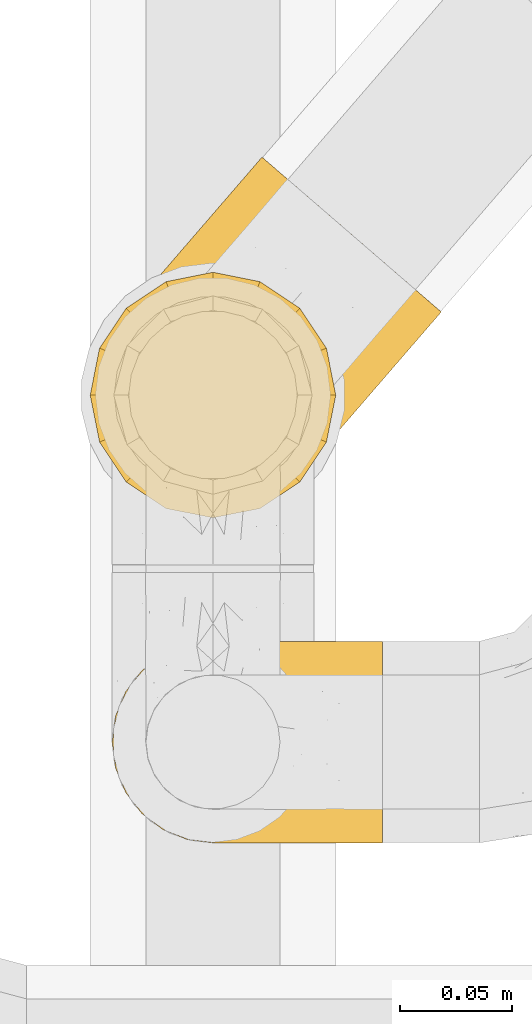
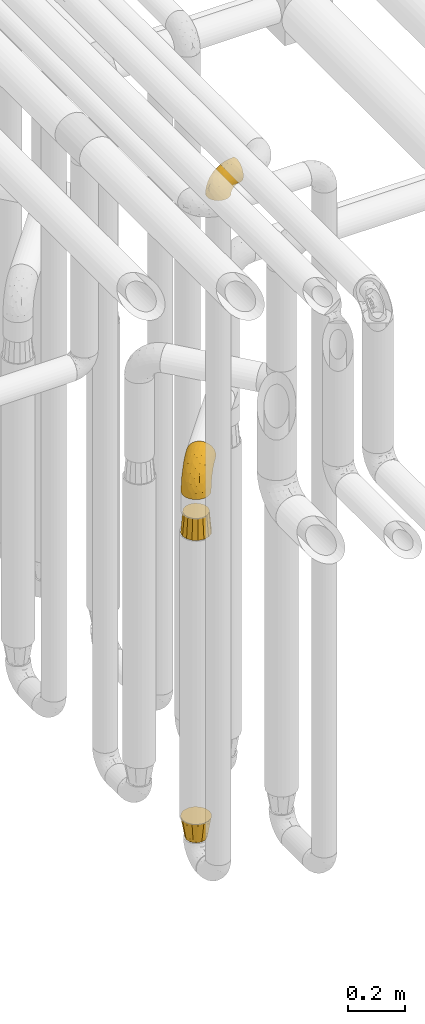
# One storey, part 194 of 827: 4 coverings.
"""IFC2X3 building model written with IfcOpenShell, lengths in millimetres."""

from ifc_helpers import new_model, entity, si_unit, converted_unit, derived_unit, direction, frame, origin, place, context, subcontext, project, spatial, faceted_brep, element, save


model = new_model("IFC2X3")

# Units and contexts
model_context = context("Model", 3, precision=0.01, world=origin(), true_north=direction((6.12303176911189e-17, 1.0)))
body_context = subcontext(model_context, "Body", "Model", "MODEL_VIEW")
ifc_project = project(units=[si_unit("LENGTHUNIT", "METRE", prefix="MILLI"), si_unit("AREAUNIT", "SQUARE_METRE"), si_unit("VOLUMEUNIT", "CUBIC_METRE"), converted_unit("PLANEANGLEUNIT", "DEGREE", entity("IfcRatioMeasure", 0.0174532925199433), si_unit("PLANEANGLEUNIT", "RADIAN"), dimensions=[0, 0, 0, 0, 0, 0, 0]), si_unit("MASSUNIT", "GRAM", prefix="KILO"), derived_unit("MASSDENSITYUNIT", [(si_unit("MASSUNIT", "GRAM", prefix="KILO"), 1), (si_unit("LENGTHUNIT", "METRE"), -3)]), derived_unit("MOMENTOFINERTIAUNIT", [(si_unit("LENGTHUNIT", "METRE"), 4)]), si_unit("TIMEUNIT", "SECOND"), si_unit("FREQUENCYUNIT", "HERTZ"), si_unit("THERMODYNAMICTEMPERATUREUNIT", "DEGREE_CELSIUS"), derived_unit("THERMALTRANSMITTANCEUNIT", [(si_unit("MASSUNIT", "GRAM", prefix="KILO"), 1), (si_unit("THERMODYNAMICTEMPERATUREUNIT", "KELVIN"), -1), (si_unit("TIMEUNIT", "SECOND"), -3)]), derived_unit("VOLUMETRICFLOWRATEUNIT", [(si_unit("LENGTHUNIT", "METRE"), 3), (si_unit("TIMEUNIT", "SECOND"), -1)]), derived_unit("MASSFLOWRATEUNIT", [(si_unit("MASSUNIT", "GRAM", prefix="KILO"), 1), (si_unit("TIMEUNIT", "SECOND"), -1)]), derived_unit("ROTATIONALFREQUENCYUNIT", [(si_unit("TIMEUNIT", "SECOND"), -1)]), si_unit("ELECTRICCURRENTUNIT", "AMPERE"), si_unit("ELECTRICVOLTAGEUNIT", "VOLT"), si_unit("POWERUNIT", "WATT"), si_unit("FORCEUNIT", "NEWTON", prefix="KILO"), si_unit("ILLUMINANCEUNIT", "LUX"), si_unit("LUMINOUSFLUXUNIT", "LUMEN"), si_unit("LUMINOUSINTENSITYUNIT", "CANDELA"), derived_unit("USERDEFINED", [(si_unit("MASSUNIT", "GRAM", prefix="KILO"), -1), (si_unit("LENGTHUNIT", "METRE"), -2), (si_unit("TIMEUNIT", "SECOND"), 3), (si_unit("LUMINOUSFLUXUNIT", "LUMEN"), 1)]), derived_unit("LINEARVELOCITYUNIT", [(si_unit("LENGTHUNIT", "METRE"), 1), (si_unit("TIMEUNIT", "SECOND"), -1)]), si_unit("PRESSUREUNIT", "PASCAL"), derived_unit("USERDEFINED", [(si_unit("LENGTHUNIT", "METRE"), -2), (si_unit("MASSUNIT", "GRAM", prefix="KILO"), 1), (si_unit("TIMEUNIT", "SECOND"), -2)]), derived_unit("LINEARFORCEUNIT", [(si_unit("MASSUNIT", "GRAM", prefix="KILO"), 1), (si_unit("LENGTHUNIT", "METRE"), 1), (si_unit("TIMEUNIT", "SECOND"), -2), (si_unit("LENGTHUNIT", "METRE"), -1)]), derived_unit("PLANARFORCEUNIT", [(si_unit("MASSUNIT", "GRAM", prefix="KILO"), 1), (si_unit("LENGTHUNIT", "METRE"), 1), (si_unit("TIMEUNIT", "SECOND"), -2), (si_unit("LENGTHUNIT", "METRE"), -2)])], contexts=[model_context])

# Site, building, storey
site_placement = place(None, origin())
site = spatial("IfcSite", under=ifc_project, at=site_placement, CompositionType="ELEMENT")
building_placement = place(site_placement, origin())
building = spatial("IfcBuilding", under=site, at=building_placement, CompositionType="ELEMENT")
storey_placement = place(building_placement, frame((0.0, 0.0, 28200.0)))
storey = spatial("IfcBuildingStorey", under=building, at=storey_placement, Name="08", CompositionType="ELEMENT", Elevation=28200.0)

# Coverings
covering_1_placement = place(storey_placement, frame((36582.9, 9879.43, 3322.4)))
element("IfcCovering", 1, at=covering_1_placement, inside=storey, Name=":ADSK_", ObjectType=":ADSK_", PredefinedType="INSULATION", context=body_context, shape_type="Brep", body=[
    faceted_brep([(122.75, 90.76, 87.65), (122.75, 87.42, 97.19), (122.75, 82.04, 105.75), (122.75, 74.89, 112.9), (122.75, 66.33, 118.28), (122.75, 56.79, 121.61), (122.75, 46.75, 122.75), (122.75, 36.69, 121.61), (122.75, 27.15, 118.27), (122.75, 18.59, 112.89), (122.75, 11.44, 105.74), (122.75, 6.06, 97.18), (122.75, 2.73, 87.64), (122.75, 1.6, 77.6), (122.75, 2.73, 67.54), (122.75, 6.07, 58.0), (122.75, 11.45, 49.44), (122.75, 18.6, 42.29), (122.75, 27.16, 36.91), (122.75, 36.7, 33.58), (122.75, 46.75, 32.45), (122.75, 56.8, 33.58), (122.75, 66.34, 36.92), (122.75, 74.9, 42.3), (122.75, 82.05, 49.45), (122.75, 87.43, 58.01), (122.75, 90.76, 67.55), (122.75, 91.9, 77.6), (90.36, 35.06, 1.6), (85.85, 24.17, 1.6), (78.67, 14.82, 1.6), (69.32, 7.64, 1.6), (58.43, 3.13, 1.6), (46.75, 1.6, 1.6), (35.06, 3.13, 1.6), (24.17, 7.64, 1.6), (14.82, 14.82, 1.6), (7.64, 24.17, 1.6), (3.13, 35.06, 1.6), (1.6, 46.75, 1.6), (3.13, 58.43, 1.6), (7.64, 69.32, 1.6), (14.82, 78.67, 1.6), (24.17, 85.85, 1.6), (35.06, 90.36, 1.6), (46.75, 91.9, 1.6), (58.43, 90.36, 1.6), (69.32, 85.85, 1.6), (78.67, 78.67, 1.6), (85.85, 69.32, 1.6), (90.36, 58.43, 1.6), (91.9, 46.75, 1.6), (51.54, 46.75, 99.61), (47.17, 55.2, 95.26), (38.13, 46.75, 86.21), (7.52, 46.75, 39.03), (5.85, 54.53, 30.75), (5.11, 46.75, 23.8), (19.2, 59.63, 60.8), (38.98, 62.07, 85.37), (35.02, 71.86, 73.64), (8.21, 62.65, 31.01), (19.28, 71.33, 49.14), (12.19, 72.93, 23.88), (101.39, 91.2, 82.74), (34.43, 86.31, 43.48), (20.95, 80.89, 29.47), (30.74, 79.49, 56.38), (72.93, 90.68, 72.18), (56.64, 86.84, 72.24), (80.81, 87.38, 87.6), (93.43, 76.87, 107.24), (100.76, 83.73, 101.1), (74.27, 81.03, 95.16), (93.66, 91.9, 71.81), (81.33, 91.9, 63.57), (69.01, 91.9, 55.34), (40.87, 91.03, 23.66), (29.38, 87.58, 20.55), (67.05, 56.52, 107.97), (85.31, 46.75, 116.82), (93.68, 60.4, 117.03), (52.53, 91.9, 30.68), (50.71, 91.9, 21.51), (48.88, 91.9, 12.33), (72.77, 67.87, 106.17), (51.21, 90.35, 52.37), (101.18, 69.57, 114.51), (100.54, 46.75, 119.23), (48.74, 79.91, 78.37), (112.01, 91.9, 75.46), (102.83, 91.9, 73.63), (73.88, 74.99, 101.51), (24.73, 46.75, 72.81), (60.77, 91.9, 43.01), (103.08, 88.53, 92.6), (54.8, 72.65, 91.86), (16.13, 46.75, 55.92), (55.92, 62.97, 99.01), (68.42, 46.75, 108.21), (104.98, 66.2, 32.05), (108.58, 56.6, 30.22), (98.21, 59.89, 23.37), (61.56, 90.95, 28.43), (60.69, 90.22, 16.44), (100.0, 76.64, 37.1), (95.88, 71.58, 28.88), (90.81, 79.99, 33.93), (84.88, 89.54, 50.17), (73.29, 89.97, 40.57), (113.4, 81.32, 47.62), (109.8, 74.56, 39.9), (102.13, 84.15, 47.92), (67.29, 90.37, 34.27), (70.34, 87.82, 24.65), (95.15, 90.98, 62.6), (105.49, 90.96, 66.18), (71.5, 85.14, 11.74), (92.87, 58.11, 13.89), (96.03, 46.75, 17.02), (81.34, 78.39, 15.86), (107.44, 88.22, 57.71), (88.36, 66.06, 9.11), (90.43, 68.6, 18.55), (114.37, 63.78, 34.74), (98.41, 88.42, 54.95), (88.73, 90.61, 57.35), (76.89, 83.8, 22.03), (86.08, 77.98, 24.8), (112.64, 91.22, 69.07), (94.21, 83.46, 42.31), (112.22, 46.75, 29.63), (107.32, 46.75, 28.31), (79.95, 84.66, 30.23), (84.51, 86.33, 40.13), (101.67, 46.75, 22.67), (94.71, 46.75, 12.12), (81.34, 15.1, 15.86), (76.89, 9.69, 22.03), (86.08, 15.52, 24.8), (79.96, 8.83, 30.23), (92.87, 35.39, 13.88), (113.41, 12.18, 47.61), (102.83, 1.6, 73.63), (105.5, 2.53, 66.17), (112.64, 2.27, 69.07), (108.58, 36.9, 30.22), (104.98, 27.31, 32.04), (98.2, 33.62, 23.36), (98.4, 5.07, 54.93), (102.13, 9.36, 47.91), (107.44, 5.27, 57.69), (88.36, 27.43, 9.1), (50.71, 1.6, 21.51), (48.88, 1.6, 12.33), (94.22, 10.05, 42.29), (100.01, 16.87, 37.09), (71.5, 8.35, 11.74), (60.69, 3.27, 16.44), (52.53, 1.6, 30.68), (95.89, 21.94, 28.86), (114.37, 29.72, 34.74), (81.33, 1.6, 63.57), (69.01, 1.6, 55.34), (84.88, 3.96, 50.17), (112.01, 1.6, 75.46), (109.8, 18.95, 39.89), (61.56, 2.54, 28.43), (67.29, 3.12, 34.27), (60.77, 1.6, 43.01), (95.14, 2.51, 62.59), (73.29, 3.52, 40.57), (84.53, 7.17, 40.13), (93.66, 1.6, 71.81), (90.82, 13.52, 33.92), (88.73, 2.88, 57.34), (70.34, 5.67, 24.65), (90.43, 24.89, 18.54), (20.95, 12.6, 29.47), (34.43, 7.18, 43.48), (30.74, 14.0, 56.4), (19.29, 22.16, 49.17), (35.07, 21.61, 73.69), (51.21, 3.14, 52.37), (56.67, 6.65, 72.26), (54.85, 20.82, 91.88), (38.98, 31.41, 85.36), (29.38, 5.91, 20.55), (40.87, 2.46, 23.66), (19.2, 33.87, 60.8), (8.21, 30.84, 31.02), (5.85, 38.96, 30.75), (12.19, 20.56, 23.9), (72.93, 2.81, 72.17), (80.83, 6.1, 87.59), (101.39, 2.29, 82.74), (93.69, 33.08, 117.03), (93.43, 16.61, 107.23), (67.04, 36.96, 107.97), (100.76, 9.75, 101.08), (72.78, 25.61, 106.17), (55.93, 30.5, 99.01), (101.18, 23.91, 114.5), (74.27, 12.45, 95.15), (73.89, 18.49, 101.5), (103.09, 4.96, 92.59), (48.78, 13.56, 78.38), (47.19, 38.28, 95.27)], [[[0, 1, 2, 3, 4, 5, 6, 7, 8, 9, 10, 11, 12, 13, 14, 15, 16, 17, 18, 19, 20, 21, 22, 23, 24, 25, 26, 27]], [[28, 29, 30, 31, 32, 33, 34, 35, 36, 37, 38, 39, 40, 41, 42, 43, 44, 45, 46, 47, 48, 49, 50, 51]], [[52, 53, 54]], [[55, 56, 57]], [[58, 59, 60]], [[61, 62, 63]], [[27, 64, 0]], [[65, 66, 67]], [[41, 40, 61]], [[68, 69, 70]], [[66, 43, 42]], [[63, 42, 41]], [[71, 72, 73]], [[72, 2, 1]], [[68, 74, 75, 76]], [[45, 44, 77]], [[43, 78, 44]], [[79, 80, 81]], [[77, 82, 83, 84, 45]], [[79, 81, 85]], [[71, 2, 72]], [[65, 86, 77]], [[4, 81, 5]], [[66, 65, 78]], [[4, 3, 87]], [[81, 88, 5]], [[63, 66, 42]], [[68, 70, 64]], [[67, 60, 89]], [[71, 3, 2]], [[64, 27, 90, 91, 74]], [[92, 71, 73]], [[40, 57, 56]], [[59, 93, 54]], [[86, 76, 94, 82]], [[1, 0, 95]], [[58, 62, 61]], [[60, 96, 89]], [[85, 81, 87]], [[56, 97, 58]], [[65, 67, 69]], [[87, 81, 4]], [[67, 89, 69]], [[61, 63, 41]], [[95, 72, 1]], [[73, 72, 70]], [[69, 73, 70]], [[73, 89, 96]], [[3, 71, 87]], [[85, 87, 71]], [[58, 61, 56]], [[59, 58, 93]], [[76, 86, 68]], [[69, 89, 73]], [[68, 86, 69]], [[65, 69, 86]], [[68, 64, 74]], [[95, 64, 70]], [[98, 79, 85]], [[79, 52, 99, 80]], [[66, 62, 67]], [[62, 58, 60]], [[62, 60, 67]], [[59, 98, 96]], [[59, 96, 60]], [[96, 85, 92]], [[88, 81, 80]], [[88, 6, 5]], [[66, 63, 62]], [[64, 95, 0]], [[72, 95, 70]], [[77, 44, 78]], [[86, 82, 77]], [[40, 39, 57]], [[96, 98, 85]], [[40, 56, 61]], [[66, 78, 43]], [[77, 78, 65]], [[79, 98, 53]], [[96, 92, 73]], [[85, 71, 92]], [[97, 56, 55]], [[97, 93, 58]], [[53, 98, 59]], [[54, 53, 59]], [[79, 53, 52]], [[100, 101, 102]], [[46, 45, 84, 83]], [[103, 104, 82]], [[82, 104, 83]], [[105, 106, 107]], [[108, 109, 76]], [[110, 111, 112]], [[103, 113, 114]], [[115, 74, 116]], [[48, 47, 117]], [[118, 102, 119]], [[49, 48, 120]], [[74, 91, 116]], [[116, 121, 115]], [[49, 122, 50]], [[123, 106, 102]], [[124, 111, 22]], [[125, 126, 115]], [[23, 22, 111]], [[24, 110, 121]], [[120, 127, 128]], [[90, 26, 129]], [[27, 26, 90]], [[121, 125, 115]], [[24, 121, 25]], [[130, 105, 107]], [[129, 25, 116]], [[21, 20, 131]], [[120, 123, 122]], [[112, 105, 130]], [[50, 118, 51]], [[21, 124, 22]], [[101, 131, 132]], [[117, 120, 48]], [[24, 23, 110]], [[127, 114, 133]], [[75, 108, 76]], [[107, 134, 130]], [[133, 114, 113]], [[129, 116, 91]], [[25, 121, 116]], [[121, 112, 125]], [[75, 74, 115]], [[101, 135, 102]], [[131, 101, 21]], [[101, 100, 124]], [[128, 127, 133]], [[119, 136, 51, 118]], [[104, 47, 46]], [[83, 104, 46]], [[117, 104, 114]], [[101, 124, 21]], [[111, 124, 100]], [[102, 118, 123]], [[133, 134, 107]], [[111, 110, 23]], [[114, 104, 103]], [[94, 76, 109]], [[121, 110, 112]], [[122, 118, 50]], [[134, 109, 108]], [[133, 107, 128]], [[112, 108, 125]], [[126, 125, 108]], [[108, 75, 126]], [[75, 115, 126]], [[109, 134, 133]], [[130, 108, 112]], [[108, 130, 134]], [[105, 112, 111]], [[111, 100, 105]], [[106, 105, 100]], [[102, 106, 100]], [[128, 106, 123]], [[90, 129, 91]], [[25, 129, 26]], [[104, 117, 47]], [[117, 114, 127]], [[82, 94, 103]], [[113, 94, 109]], [[94, 113, 103]], [[133, 113, 109]], [[106, 128, 107]], [[123, 120, 128]], [[120, 122, 49]], [[118, 122, 123]], [[135, 101, 132]], [[135, 119, 102]], [[117, 127, 120]], [[30, 29, 137]], [[138, 139, 140]], [[51, 136, 119, 141]], [[142, 17, 16]], [[143, 144, 145]], [[146, 147, 148]], [[149, 150, 151]], [[152, 29, 28]], [[33, 32, 153, 154]], [[150, 155, 156]], [[157, 31, 30]], [[153, 158, 159]], [[29, 152, 137]], [[148, 141, 119]], [[156, 160, 147]], [[148, 135, 146]], [[137, 138, 157]], [[19, 161, 146]], [[162, 163, 164]], [[14, 13, 165]], [[153, 32, 158]], [[147, 161, 166]], [[18, 17, 166]], [[167, 168, 169]], [[166, 150, 156]], [[151, 150, 142]], [[151, 170, 149]], [[151, 16, 15]], [[171, 140, 172]], [[165, 143, 145]], [[173, 170, 144]], [[142, 166, 17]], [[19, 131, 20]], [[144, 170, 151]], [[18, 161, 19]], [[173, 144, 143]], [[140, 139, 174]], [[171, 164, 163]], [[164, 172, 155]], [[151, 15, 144]], [[145, 15, 14]], [[173, 162, 170]], [[149, 175, 164]], [[19, 146, 131]], [[132, 131, 146]], [[160, 148, 147]], [[159, 158, 167]], [[135, 132, 146]], [[158, 32, 31]], [[157, 158, 31]], [[167, 158, 176]], [[166, 161, 18]], [[146, 161, 147]], [[148, 177, 141]], [[171, 168, 140]], [[171, 163, 169]], [[151, 142, 16]], [[166, 142, 150]], [[152, 141, 177]], [[51, 141, 28]], [[138, 140, 176]], [[172, 140, 174]], [[175, 149, 170]], [[164, 150, 149]], [[170, 162, 175]], [[162, 164, 175]], [[155, 172, 174]], [[171, 172, 164]], [[155, 174, 156]], [[164, 155, 150]], [[160, 156, 174]], [[147, 166, 156]], [[139, 160, 174]], [[148, 160, 177]], [[15, 145, 144]], [[165, 145, 14]], [[137, 157, 30]], [[158, 157, 176]], [[168, 167, 176]], [[169, 159, 167]], [[140, 168, 176]], [[169, 168, 171]], [[137, 177, 139]], [[160, 139, 177]], [[141, 152, 28]], [[137, 152, 177]], [[148, 119, 135]], [[157, 138, 176]], [[139, 138, 137]], [[178, 179, 180]], [[181, 180, 182]], [[179, 183, 184]], [[185, 186, 182]], [[187, 188, 179]], [[188, 33, 154, 153, 159]], [[181, 189, 190]], [[35, 34, 187]], [[191, 38, 190]], [[192, 178, 181]], [[179, 184, 180]], [[192, 190, 37]], [[37, 190, 38]], [[36, 35, 178]], [[54, 93, 186]], [[35, 187, 178]], [[193, 194, 184]], [[195, 173, 143, 165, 13]], [[195, 193, 173]], [[193, 163, 162, 173]], [[13, 12, 195]], [[8, 7, 196]], [[9, 197, 10]], [[198, 80, 99, 52]], [[196, 7, 88]], [[197, 199, 10]], [[182, 189, 181]], [[200, 198, 201]], [[200, 196, 198]], [[9, 8, 202]], [[194, 199, 203]], [[192, 37, 36]], [[80, 196, 88]], [[183, 159, 169, 163]], [[188, 34, 33]], [[202, 200, 197]], [[185, 203, 204]], [[202, 8, 196]], [[10, 199, 11]], [[12, 11, 205]], [[38, 191, 57]], [[189, 97, 191]], [[203, 199, 197]], [[205, 199, 194]], [[204, 203, 197]], [[184, 203, 206]], [[200, 202, 196]], [[197, 9, 202]], [[207, 54, 186]], [[97, 55, 191]], [[194, 203, 184]], [[183, 163, 193]], [[184, 206, 180]], [[183, 193, 184]], [[205, 195, 12]], [[193, 195, 194]], [[80, 198, 196]], [[207, 186, 201]], [[182, 180, 206]], [[181, 178, 180]], [[185, 182, 206]], [[182, 186, 189]], [[203, 185, 206]], [[185, 200, 201]], [[7, 6, 88]], [[178, 192, 36]], [[190, 192, 181]], [[199, 205, 11]], [[195, 205, 194]], [[159, 183, 188]], [[179, 188, 183]], [[57, 191, 55]], [[57, 39, 38]], [[189, 191, 190]], [[188, 187, 34]], [[178, 187, 179]], [[186, 93, 189]], [[197, 200, 204]], [[185, 204, 200]], [[189, 93, 97]], [[207, 198, 52]], [[185, 201, 186]], [[198, 207, 201]], [[54, 207, 52]]]),
])
covering_2_placement = place(storey_placement, frame((36575.14, 10027.09, 1953.4)))
element("IfcCovering", 2, at=covering_2_placement, inside=storey, Name=":ADSK_", ObjectType=":ADSK_", PredefinedType="INSULATION", context=body_context, shape_type="Brep", body=[
    faceted_brep([(107.67, 134.11, 148.32), (116.6, 126.4, 149.65), (125.54, 118.68, 148.31), (134.02, 111.35, 144.39), (141.64, 104.78, 138.06), (147.99, 99.29, 129.66), (152.77, 95.16, 119.6), (155.74, 92.6, 108.39), (156.75, 91.73, 96.6), (155.74, 92.6, 84.79), (152.77, 95.16, 73.57), (147.98, 99.3, 63.51), (141.62, 104.79, 55.11), (134.01, 111.36, 48.79), (125.52, 118.69, 44.87), (116.6, 126.4, 43.55), (107.66, 134.12, 44.88), (99.17, 141.45, 48.8), (91.56, 148.03, 55.13), (85.2, 153.52, 63.53), (80.42, 157.65, 73.59), (77.45, 160.21, 84.8), (76.45, 161.08, 96.6), (77.46, 160.21, 108.41), (80.43, 157.64, 119.62), (85.21, 153.51, 129.68), (91.57, 148.02, 138.08), (99.19, 141.44, 144.4), (98.39, 84.31, 1.6), (104.61, 71.94, 1.6), (107.41, 58.38, 1.6), (106.61, 44.55, 1.6), (102.26, 31.4, 1.6), (94.65, 19.83, 1.6), (84.31, 10.62, 1.6), (71.94, 4.4, 1.6), (58.38, 1.6, 1.6), (44.55, 2.4, 1.6), (31.4, 6.75, 1.6), (19.83, 14.35, 1.6), (10.62, 24.7, 1.6), (4.4, 37.07, 1.6), (1.6, 50.63, 1.6), (2.4, 64.46, 1.6), (6.75, 77.61, 1.6), (14.35, 89.18, 1.6), (24.7, 98.39, 1.6), (37.07, 104.61, 1.6), (50.63, 107.41, 1.6), (64.46, 106.61, 1.6), (77.61, 102.26, 1.6), (89.18, 94.65, 1.6), (4.6, 43.97, 27.97), (10.75, 32.58, 37.09), (11.35, 49.1, 58.27), (14.61, 22.96, 27.13), (23.13, 18.17, 39.91), (40.19, 102.31, 109.11), (26.63, 81.46, 94.41), (38.06, 81.09, 110.94), (28.38, 49.84, 89.69), (32.79, 29.37, 75.62), (48.17, 47.17, 106.28), (14.38, 82.75, 60.12), (6.93, 70.2, 41.41), (12.66, 74.07, 63.22), (8.85, 79.33, 32.05), (17.15, 91.03, 52.13), (52.18, 105.6, 123.27), (57.44, 96.06, 129.32), (74.21, 118.09, 138.3), (16.51, 40.14, 62.95), (19.99, 29.06, 55.89), (4.75, 58.25, 37.4), (91.55, 97.4, 144.6), (80.99, 109.79, 142.66), (48.25, 68.16, 117.85), (66.53, 85.87, 134.01), (26.94, 93.1, 89.25), (60.75, 141.51, 103.34), (61.06, 136.99, 113.52), (26.21, 102.91, 57.43), (21.8, 97.8, 44.19), (17.39, 92.7, 30.95), (27.75, 102.2, 77.98), (71.12, 128.74, 132.66), (58.19, 124.23, 121.52), (22.41, 63.02, 86.93), (13.44, 66.09, 68.4), (39.95, 118.82, 78.45), (33.08, 110.86, 67.94), (67.92, 151.2, 94.53), (57.26, 138.86, 91.95), (44.1, 122.24, 93.36), (48.61, 128.84, 85.2), (41.39, 114.03, 101.45), (68.21, 70.38, 129.81), (15.87, 90.94, 16.27), (84.66, 123.6, 42.46), (72.54, 120.72, 40.4), (69.68, 127.87, 49.71), (29.44, 104.45, 39.4), (37.2, 107.83, 31.26), (26.84, 101.17, 27.7), (23.24, 97.73, 16.7), (52.59, 129.87, 70.67), (58.65, 139.0, 81.69), (36.2, 105.13, 16.68), (92.85, 98.91, 22.57), (91.4, 97.22, 14.26), (80.23, 104.28, 17.68), (53.66, 109.7, 19.58), (53.51, 114.06, 33.49), (64.11, 115.28, 33.01), (96.2, 119.91, 40.69), (108.32, 116.82, 40.15), (102.89, 110.53, 37.93), (84.5, 111.08, 31.04), (46.85, 116.28, 45.29), (69.41, 110.3, 23.55), (69.57, 106.34, 11.36), (40.22, 116.38, 59.1), (53.33, 124.87, 57.42), (43.45, 121.37, 68.96), (43.93, 108.21, 20.38), (67.53, 143.7, 72.46), (68.16, 149.48, 83.66), (66.67, 135.07, 60.66), (78.27, 143.79, 61.01), (81.44, 135.04, 51.85), (94.55, 131.12, 46.07), (97.87, 104.72, 30.25), (35.71, 110.22, 46.65), (60.92, 120.42, 43.0), (109.23, 61.7, 19.58), (140.85, 80.39, 72.44), (100.01, 87.2, 17.67), (120.25, 49.47, 78.45), (122.27, 53.3, 68.97), (129.34, 63.58, 70.65), (113.13, 105.28, 40.69), (118.47, 94.41, 42.45), (106.11, 92.44, 31.04), (118.78, 70.47, 42.99), (116.68, 55.86, 45.18), (113.57, 62.25, 33.46), (132.43, 78.28, 60.64), (124.27, 63.59, 57.37), (106.51, 33.56, 57.43), (102.1, 28.45, 44.19), (107.56, 36.99, 39.35), (96.17, 21.59, 16.27), (101.82, 29.86, 16.7), (137.56, 69.51, 91.95), (128.9, 59.49, 85.2), (137.47, 70.87, 81.68), (112.33, 43.96, 46.68), (109.79, 45.14, 31.26), (107.25, 43.76, 16.68), (104.7, 33.93, 27.7), (139.37, 91.02, 60.99), (130.25, 92.9, 51.84), (117.4, 82.02, 40.41), (124.88, 80.21, 49.72), (124.46, 105.29, 46.06), (148.22, 81.85, 94.53), (103.59, 76.95, 11.35), (113.23, 72.91, 33.02), (146.47, 81.84, 83.65), (109.18, 51.86, 20.38), (113.38, 41.51, 67.94), (107.53, 77.37, 23.53), (117.8, 49.36, 59.12), (97.69, 23.35, 30.95), (55.44, 11.03, 58.27), (51.34, 3.6, 27.97), (65.45, 5.82, 37.4), (76.96, 9.72, 41.41), (29.12, 10.45, 27.21), (39.18, 8.03, 37.09), (33.69, 15.86, 53.2), (96.08, 22.87, 52.13), (139.67, 73.35, 103.34), (135.17, 73.0, 113.5), (115.3, 50.19, 101.45), (85.23, 30.85, 94.41), (103.9, 47.29, 109.08), (83.23, 42.12, 110.95), (123.03, 54.08, 93.36), (105.59, 34.98, 77.98), (85.72, 12.95, 32.05), (45.76, 15.62, 64.63), (105.41, 59.63, 123.25), (125.55, 81.75, 132.65), (95.22, 63.46, 129.32), (119.6, 89.05, 139.96), (68.92, 50.3, 117.85), (53.69, 27.98, 89.69), (122.98, 68.31, 121.51), (79.95, 15.96, 63.23), (96.67, 32.8, 89.17), (105.37, 88.75, 142.66), (71.94, 15.56, 68.4), (67.6, 24.0, 86.94), (88.29, 18.92, 60.12), (85.71, 69.09, 133.2)], [[[0, 1, 2, 3, 4, 5, 6, 7, 8, 9, 10, 11, 12, 13, 14, 15, 16, 17, 18, 19, 20, 21, 22, 23, 24, 25, 26, 27]], [[28, 29, 30, 31, 32, 33, 34, 35, 36, 37, 38, 39, 40, 41, 42, 43, 44, 45, 46, 47, 48, 49, 50, 51]], [[52, 53, 54]], [[55, 39, 56]], [[57, 58, 59]], [[60, 61, 62]], [[63, 64, 65]], [[66, 63, 67]], [[68, 69, 70]], [[53, 71, 54]], [[41, 40, 53]], [[53, 72, 71]], [[73, 42, 52]], [[42, 41, 52]], [[74, 0, 75]], [[69, 76, 77]], [[43, 73, 64]], [[45, 44, 66]], [[57, 78, 58]], [[23, 79, 80]], [[67, 81, 82, 83]], [[67, 84, 81]], [[24, 23, 80]], [[25, 85, 26]], [[86, 85, 25]], [[42, 73, 43]], [[0, 27, 75]], [[25, 24, 86]], [[70, 26, 85]], [[0, 74, 1]], [[68, 85, 86]], [[66, 64, 63]], [[60, 59, 87]], [[54, 87, 88]], [[76, 60, 62]], [[84, 89, 90, 81]], [[79, 22, 91, 92]], [[77, 74, 75]], [[93, 92, 94, 89]], [[80, 86, 24]], [[40, 55, 53]], [[76, 59, 60]], [[93, 84, 95]], [[76, 62, 96]], [[55, 72, 53]], [[70, 27, 26]], [[75, 70, 69]], [[78, 84, 63]], [[93, 79, 92]], [[95, 86, 80]], [[77, 76, 96]], [[59, 69, 68]], [[57, 68, 86]], [[68, 57, 59]], [[59, 58, 87]], [[76, 69, 59]], [[88, 87, 58]], [[87, 54, 71]], [[86, 95, 57]], [[78, 57, 95]], [[84, 78, 95]], [[78, 63, 65]], [[58, 78, 65]], [[54, 88, 73]], [[84, 93, 89]], [[79, 95, 80]], [[79, 93, 95]], [[22, 79, 23]], [[66, 83, 97, 45]], [[84, 67, 63]], [[83, 66, 67]], [[64, 44, 43]], [[64, 66, 44]], [[65, 73, 88]], [[53, 52, 41]], [[73, 52, 54]], [[73, 65, 64]], [[65, 88, 58]], [[39, 55, 40]], [[72, 55, 56]], [[56, 61, 72]], [[60, 72, 61]], [[72, 60, 71]], [[87, 71, 60]], [[27, 70, 75]], [[68, 70, 85]], [[74, 77, 96]], [[69, 77, 75]], [[98, 99, 100]], [[46, 45, 97]], [[101, 102, 103]], [[103, 104, 83]], [[105, 94, 106]], [[107, 103, 102]], [[108, 109, 51, 110]], [[111, 112, 113]], [[114, 115, 116]], [[47, 104, 107]], [[110, 117, 108]], [[49, 48, 111]], [[102, 118, 112]], [[119, 120, 111]], [[50, 49, 120]], [[121, 122, 118]], [[105, 123, 89]], [[124, 48, 107]], [[20, 19, 125]], [[121, 81, 90]], [[117, 119, 99]], [[21, 20, 126]], [[22, 21, 91]], [[105, 125, 127]], [[110, 51, 50]], [[19, 128, 125]], [[16, 15, 115]], [[129, 98, 100]], [[126, 91, 21]], [[128, 129, 127]], [[122, 123, 105]], [[114, 117, 98]], [[17, 16, 130]], [[18, 128, 19]], [[129, 18, 17]], [[125, 106, 126]], [[115, 114, 16]], [[130, 129, 17]], [[114, 98, 130]], [[117, 116, 131, 108]], [[99, 119, 113]], [[122, 121, 123]], [[92, 126, 106]], [[105, 127, 122]], [[132, 121, 118]], [[114, 130, 16]], [[129, 130, 98]], [[50, 120, 110]], [[129, 128, 18]], [[125, 128, 127]], [[125, 126, 20]], [[91, 126, 92]], [[105, 89, 94]], [[105, 106, 125]], [[94, 92, 106]], [[100, 122, 127]], [[118, 122, 133]], [[112, 118, 133]], [[132, 118, 102]], [[132, 102, 101]], [[81, 121, 132]], [[82, 103, 83]], [[132, 101, 81]], [[104, 47, 46]], [[124, 107, 102]], [[48, 47, 107]], [[113, 112, 133]], [[112, 111, 124]], [[99, 113, 133]], [[111, 113, 119]], [[99, 133, 100]], [[117, 99, 98]], [[122, 100, 133]], [[127, 129, 100]], [[103, 82, 101]], [[81, 101, 82]], [[112, 124, 102]], [[48, 124, 111]], [[104, 103, 107]], [[46, 97, 104]], [[111, 120, 49]], [[83, 104, 97]], [[110, 120, 119]], [[117, 110, 119]], [[116, 117, 114]], [[89, 123, 90]], [[90, 123, 121]], [[30, 29, 134]], [[11, 10, 135]], [[51, 109, 108, 136]], [[137, 138, 139]], [[140, 141, 142]], [[143, 144, 145]], [[146, 139, 147]], [[148, 149, 150]], [[151, 32, 152]], [[153, 154, 155]], [[156, 150, 157]], [[158, 157, 159]], [[108, 142, 136]], [[31, 158, 152]], [[160, 161, 12]], [[162, 163, 143]], [[140, 142, 116]], [[142, 141, 162]], [[14, 164, 140]], [[14, 140, 115]], [[9, 8, 165]], [[160, 12, 11]], [[141, 164, 161]], [[13, 12, 161]], [[14, 115, 15]], [[28, 166, 29]], [[135, 139, 146]], [[141, 163, 162]], [[135, 146, 160]], [[143, 167, 162]], [[29, 166, 134]], [[116, 142, 108, 131]], [[165, 153, 168]], [[10, 9, 168]], [[168, 135, 10]], [[138, 147, 139]], [[158, 169, 157]], [[14, 13, 164]], [[116, 115, 140]], [[145, 167, 143]], [[135, 160, 11]], [[168, 153, 155]], [[138, 137, 170]], [[157, 144, 156]], [[147, 144, 143]], [[161, 164, 13]], [[140, 164, 141]], [[142, 171, 136]], [[136, 171, 166]], [[161, 160, 146]], [[165, 168, 9]], [[155, 139, 135]], [[139, 154, 137]], [[168, 155, 135]], [[139, 155, 154]], [[144, 147, 172]], [[163, 147, 143]], [[156, 144, 172]], [[157, 169, 145]], [[172, 148, 156]], [[173, 159, 149]], [[159, 157, 150]], [[152, 159, 173]], [[159, 152, 158]], [[31, 30, 158]], [[169, 30, 134]], [[157, 145, 144]], [[167, 134, 171]], [[134, 167, 145]], [[171, 142, 162]], [[162, 167, 171]], [[163, 141, 161]], [[161, 146, 163]], [[147, 163, 146]], [[148, 150, 156]], [[149, 159, 150]], [[30, 169, 158]], [[145, 169, 134]], [[151, 33, 32]], [[31, 152, 32]], [[152, 173, 151]], [[28, 51, 136]], [[134, 166, 171]], [[28, 136, 166]], [[138, 170, 172]], [[147, 138, 172]], [[148, 172, 170]], [[174, 175, 176]], [[35, 34, 177]], [[178, 179, 180]], [[181, 173, 149, 148]], [[182, 183, 184]], [[185, 186, 187]], [[188, 189, 137]], [[190, 33, 151, 173]], [[191, 179, 174]], [[34, 190, 177]], [[39, 38, 178]], [[192, 193, 194]], [[4, 3, 195]], [[175, 179, 37]], [[38, 37, 179]], [[35, 176, 36]], [[196, 62, 197]], [[181, 190, 173]], [[37, 36, 175]], [[183, 6, 198]], [[189, 148, 170, 137]], [[185, 199, 200]], [[3, 2, 201]], [[202, 185, 203]], [[8, 7, 182]], [[200, 184, 186]], [[183, 7, 6]], [[181, 189, 204]], [[200, 189, 184]], [[5, 198, 6]], [[187, 203, 185]], [[195, 3, 201]], [[205, 196, 194]], [[62, 61, 197]], [[186, 198, 192]], [[180, 179, 191]], [[2, 1, 74]], [[198, 193, 192]], [[193, 5, 4]], [[194, 193, 195]], [[2, 74, 201]], [[5, 193, 198]], [[205, 74, 96]], [[188, 137, 154, 153]], [[62, 196, 96]], [[56, 178, 180]], [[198, 184, 183]], [[184, 188, 182]], [[203, 197, 191]], [[205, 194, 201]], [[187, 192, 194]], [[192, 187, 186]], [[194, 196, 187]], [[197, 187, 196]], [[197, 203, 187]], [[202, 174, 176]], [[200, 186, 185]], [[184, 198, 186]], [[199, 185, 202]], [[189, 200, 204]], [[174, 202, 203]], [[176, 177, 199]], [[189, 181, 148]], [[190, 181, 204]], [[190, 204, 177]], [[190, 34, 33]], [[188, 153, 182]], [[189, 188, 184]], [[182, 153, 165, 8]], [[183, 182, 7]], [[199, 177, 204]], [[35, 177, 176]], [[176, 175, 36]], [[179, 175, 174]], [[200, 199, 204]], [[176, 199, 202]], [[203, 191, 174]], [[180, 197, 61]], [[197, 180, 191]], [[61, 56, 180]], [[39, 178, 56]], [[38, 179, 178]], [[194, 195, 201]], [[4, 195, 193]], [[74, 205, 201]], [[96, 196, 205]]]),
])
covering_3_placement = place(storey_placement, frame((36573.05, 10025.0, 1781.0)))
element("IfcCovering", 3, at=covering_3_placement, inside=storey, Name=":ADSK_", ObjectType=":ADSK_", PredefinedType="INSULATION", context=body_context, shape_type="Brep", body=[
    faceted_brep([(35.55, 107.41, 0.0), (43.51, 108.99, 0.0), (56.6, 111.6, 0.0), (69.69, 108.99, 0.0), (77.64, 107.41, 0.0), (86.56, 101.45, 0.0), (95.49, 95.49, 0.0), (101.45, 86.56, 0.0), (107.41, 77.64, 0.0), (108.99, 69.69, 0.0), (111.6, 56.6, 0.0), (108.99, 43.51, 0.0), (107.41, 35.55, 0.0), (101.45, 26.63, 0.0), (95.49, 17.7, 0.0), (86.56, 11.74, 0.0), (77.64, 5.78, 0.0), (69.69, 4.2, 0.0), (56.6, 1.6, 0.0), (43.51, 4.2, 0.0), (35.55, 5.78, 0.0), (26.63, 11.74, 0.0), (17.7, 17.7, 0.0), (11.74, 26.63, 0.0), (5.78, 35.55, 0.0), (4.2, 43.51, 0.0), (1.6, 56.6, 0.0), (4.2, 69.69, 0.0), (5.78, 77.64, 0.0), (11.74, 86.56, 0.0), (17.7, 95.49, 0.0), (26.63, 101.45, 0.0), (9.1, 56.6, 89.0), (10.9, 47.51, 89.0), (12.71, 38.42, 89.0), (17.86, 30.71, 89.0), (23.01, 23.01, 89.0), (30.71, 17.86, 89.0), (38.42, 12.71, 89.0), (47.51, 10.9, 89.0), (56.6, 9.1, 89.0), (65.68, 10.9, 89.0), (74.77, 12.71, 89.0), (82.48, 17.86, 89.0), (90.18, 23.01, 89.0), (95.33, 30.71, 89.0), (100.48, 38.42, 89.0), (102.29, 47.51, 89.0), (104.1, 56.6, 89.0), (102.29, 65.68, 89.0), (100.48, 74.77, 89.0), (95.33, 82.48, 89.0), (90.18, 90.18, 89.0), (82.48, 95.33, 89.0), (74.77, 100.48, 89.0), (65.68, 102.29, 89.0), (56.6, 104.1, 89.0), (47.51, 102.29, 89.0), (38.42, 100.48, 89.0), (30.71, 95.33, 89.0), (23.01, 90.18, 89.0), (17.86, 82.48, 89.0), (12.71, 74.77, 89.0), (10.9, 65.68, 89.0)], [[[0, 1, 2, 3, 4, 5, 6, 7, 8, 9, 10, 11, 12, 13, 14, 15, 16, 17, 18, 19, 20, 21, 22, 23, 24, 25, 26, 27, 28, 29, 30, 31]], [[32, 33, 34, 35, 36, 37, 38, 39, 40, 41, 42, 43, 44, 45, 46, 47, 48, 49, 50, 51, 52, 53, 54, 55, 56, 57, 58, 59, 60, 61, 62, 63]], [[46, 12, 11, 10, 48, 47]], [[44, 14, 13, 12, 46, 45]], [[42, 16, 15, 14, 44, 43]], [[41, 40, 18, 17, 16, 42]], [[38, 20, 19, 18, 40, 39]], [[36, 22, 21, 20, 38, 37]], [[34, 24, 23, 22, 36, 35]], [[33, 32, 26, 25, 24, 34]], [[62, 28, 27, 26, 32, 63]], [[60, 30, 29, 28, 62, 61]], [[58, 0, 31, 30, 60, 59]], [[57, 56, 2, 1, 0, 58]], [[54, 4, 3, 2, 56, 55]], [[52, 6, 5, 4, 54, 53]], [[50, 8, 7, 6, 52, 51]], [[49, 48, 10, 9, 8, 50]]]),
])
covering_4_placement = place(storey_placement, frame((36573.05, 10025.0, 476.0)))
element("IfcCovering", 4, at=covering_4_placement, inside=storey, Name=":ADSK_", ObjectType=":ADSK_", PredefinedType="INSULATION", context=body_context, shape_type="Brep", body=[
    faceted_brep([(77.64, 107.41, 89.0), (67.12, 109.5, 89.0), (56.6, 111.6, 89.0), (46.07, 109.5, 89.0), (35.55, 107.41, 89.0), (26.63, 101.45, 89.0), (17.7, 95.49, 89.0), (11.74, 86.56, 89.0), (5.78, 77.64, 89.0), (3.69, 67.12, 89.0), (1.6, 56.6, 89.0), (3.69, 46.07, 89.0), (5.78, 35.55, 89.0), (11.74, 26.63, 89.0), (17.7, 17.7, 89.0), (26.63, 11.74, 89.0), (35.55, 5.78, 89.0), (46.07, 3.69, 89.0), (56.6, 1.6, 89.0), (67.12, 3.69, 89.0), (77.64, 5.78, 89.0), (86.56, 11.74, 89.0), (95.49, 17.7, 89.0), (101.45, 26.63, 89.0), (107.41, 35.55, 89.0), (109.5, 46.07, 89.0), (111.6, 56.6, 89.0), (109.5, 67.12, 89.0), (107.41, 77.64, 89.0), (101.45, 86.56, 89.0), (95.49, 95.49, 89.0), (86.56, 101.45, 89.0), (91.24, 36.6, 0.0), (83.92, 29.27, 0.0), (76.6, 21.95, 0.0), (66.6, 19.27, 0.0), (56.6, 16.6, 0.0), (46.6, 19.27, 0.0), (36.6, 21.95, 0.0), (29.27, 29.27, 0.0), (21.95, 36.6, 0.0), (19.27, 46.6, 0.0), (16.6, 56.6, 0.0), (19.27, 66.6, 0.0), (21.95, 76.6, 0.0), (29.27, 83.92, 0.0), (36.6, 91.24, 0.0), (46.6, 93.92, 0.0), (56.6, 96.6, 0.0), (66.6, 93.92, 0.0), (76.6, 91.24, 0.0), (83.92, 83.92, 0.0), (91.24, 76.6, 0.0), (93.92, 66.6, 0.0), (96.6, 56.6, 0.0), (93.92, 46.6, 0.0)], [[[0, 1, 2, 3, 4, 5, 6, 7, 8, 9, 10, 11, 12, 13, 14, 15, 16, 17, 18, 19, 20, 21, 22, 23, 24, 25, 26, 27, 28, 29, 30, 31]], [[32, 33, 34, 35, 36, 37, 38, 39, 40, 41, 42, 43, 44, 45, 46, 47, 48, 49, 50, 51, 52, 53, 54, 55]], [[3, 2, 48]], [[44, 7, 45]], [[45, 5, 46]], [[48, 47, 3]], [[6, 45, 7]], [[44, 8, 7]], [[5, 45, 6]], [[42, 9, 43]], [[5, 4, 46]], [[47, 46, 4]], [[9, 42, 10]], [[8, 44, 43]], [[9, 8, 43]], [[47, 4, 3]], [[11, 10, 42]], [[38, 15, 39]], [[39, 13, 40]], [[42, 41, 11]], [[14, 39, 15]], [[38, 16, 15]], [[13, 39, 14]], [[36, 17, 37]], [[13, 12, 40]], [[41, 40, 12]], [[17, 36, 18]], [[16, 38, 37]], [[17, 16, 37]], [[41, 12, 11]], [[19, 18, 36]], [[32, 23, 33]], [[33, 21, 34]], [[36, 35, 19]], [[22, 33, 23]], [[32, 24, 23]], [[21, 33, 22]], [[54, 25, 55]], [[21, 20, 34]], [[35, 34, 20]], [[25, 54, 26]], [[24, 32, 55]], [[25, 24, 55]], [[35, 20, 19]], [[27, 26, 54]], [[50, 31, 51]], [[51, 29, 52]], [[54, 53, 27]], [[30, 51, 31]], [[50, 0, 31]], [[29, 51, 30]], [[48, 1, 49]], [[29, 28, 52]], [[53, 52, 28]], [[1, 48, 2]], [[0, 50, 49]], [[1, 0, 49]], [[53, 28, 27]]]),
])

save(model, "model.ifc")
